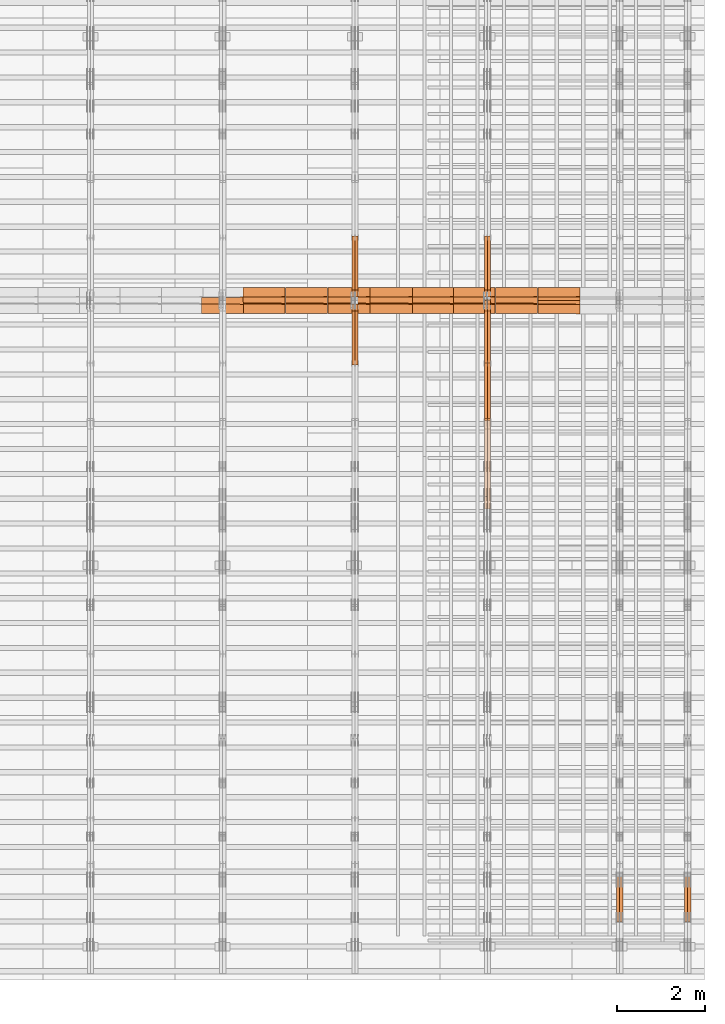
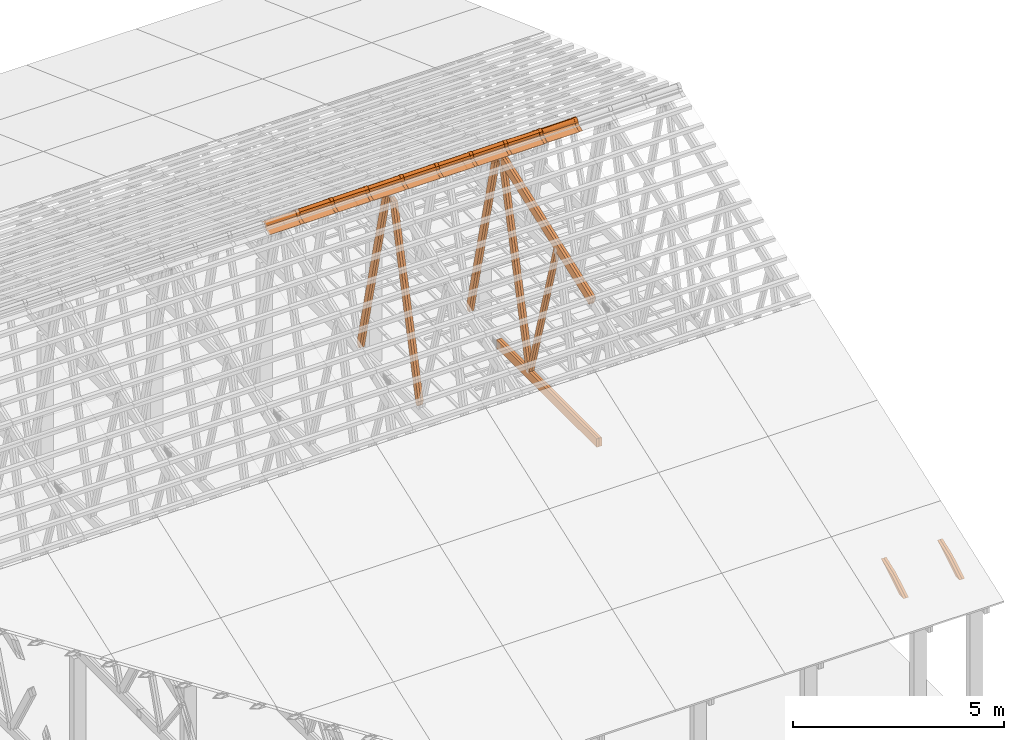
# One storey, part 53 of 189: 35 proxies.
"""IFC2X3 building model written with IfcOpenShell, lengths in millimetres."""

from ifc_helpers import new_model, entity, si_unit, converted_unit, derived_unit, direction, frame, frame_2d, origin, origin_2d_with_axis, place, context, subcontext, project, spatial, polyline, circle_curve, parameter, trimmed, segment, composite_curve, rectangle, outline, extrude, source, transform, mapped, material, type_object, type_shapes, element, save


model = new_model("IFC2X3")

# Units and contexts
model_context = context("Model", 3, precision=0.01, world=origin(), true_north=direction((6.12303176911189e-17, 1.0)))
body_context = subcontext(model_context, "Body", "Model", "MODEL_VIEW")
ifc_project = project(units=[si_unit("LENGTHUNIT", "METRE", prefix="MILLI"), si_unit("AREAUNIT", "SQUARE_METRE"), si_unit("VOLUMEUNIT", "CUBIC_METRE"), converted_unit("PLANEANGLEUNIT", "DEGREE", entity("IfcRatioMeasure", 0.0174532925199433), si_unit("PLANEANGLEUNIT", "RADIAN"), dimensions=[0, 0, 0, 0, 0, 0, 0]), si_unit("MASSUNIT", "GRAM", prefix="KILO"), derived_unit("MASSDENSITYUNIT", [(si_unit("MASSUNIT", "GRAM", prefix="KILO"), 1), (si_unit("LENGTHUNIT", "METRE"), -3)]), si_unit("TIMEUNIT", "SECOND"), si_unit("FREQUENCYUNIT", "HERTZ"), si_unit("THERMODYNAMICTEMPERATUREUNIT", "DEGREE_CELSIUS"), derived_unit("THERMALTRANSMITTANCEUNIT", [(si_unit("MASSUNIT", "GRAM", prefix="KILO"), 1), (si_unit("THERMODYNAMICTEMPERATUREUNIT", "KELVIN"), -1), (si_unit("TIMEUNIT", "SECOND"), -3)]), derived_unit("VOLUMETRICFLOWRATEUNIT", [(si_unit("LENGTHUNIT", "METRE"), 3), (si_unit("TIMEUNIT", "SECOND"), -1)]), si_unit("ELECTRICCURRENTUNIT", "AMPERE"), si_unit("ELECTRICVOLTAGEUNIT", "VOLT"), si_unit("POWERUNIT", "WATT"), si_unit("FORCEUNIT", "NEWTON"), si_unit("ILLUMINANCEUNIT", "LUX"), si_unit("LUMINOUSFLUXUNIT", "LUMEN"), si_unit("LUMINOUSINTENSITYUNIT", "CANDELA"), derived_unit("USERDEFINED", [(si_unit("MASSUNIT", "GRAM", prefix="KILO"), -1), (si_unit("LENGTHUNIT", "METRE"), -2), (si_unit("TIMEUNIT", "SECOND"), 3), (si_unit("LUMINOUSFLUXUNIT", "LUMEN"), 1)]), derived_unit("LINEARVELOCITYUNIT", [(si_unit("LENGTHUNIT", "METRE"), 1), (si_unit("TIMEUNIT", "SECOND"), -1)]), si_unit("PRESSUREUNIT", "PASCAL"), derived_unit("USERDEFINED", [(si_unit("LENGTHUNIT", "METRE"), -2), (si_unit("MASSUNIT", "GRAM", prefix="KILO"), 1), (si_unit("TIMEUNIT", "SECOND"), -2)])], contexts=[model_context])

# Site, building, storey
site_placement = place(None, origin())
site = spatial("IfcSite", under=ifc_project, at=site_placement, CompositionType="ELEMENT")
building_placement = place(site_placement, origin())
building = spatial("IfcBuilding", under=site, at=building_placement, CompositionType="ELEMENT")
storey_placement = place(building_placement, origin())
storey = spatial("IfcBuildingStorey", under=building, at=storey_placement, Name="Default", CompositionType="ELEMENT", Elevation=0.0)

# Proxies
ifc_material_1 = material(Name="IfcSurfaceStyle #270208")
building_element_proxy_type_1 = type_object("IfcBuildingElementProxyType", Name="T1-W12 270206", PredefinedType="NOTDEFINED", material=ifc_material_1)
shared_shape_1 = source(origin(), body_context, "Body", "SweptSolid", [
    extrude(outline(polyline([(-671.888430889784, -47.499785620702), (344.892972119224, -47.499785620702), (503.856463083211, 47.4997856207019), (-176.861004312651, 47.499785620702), (-671.888430889784, -47.499785620702)])), frame((503.857114243549, 47.5002636410509, 0.0), z_axis=(0.0, 0.0, 1.0), x_axis=(-1.0, 0.0, 0.0)), (0.0, 0.0, 1.0), 69.9999999999999),
])
type_shapes(building_element_proxy_type_1, [shared_shape_1])
proxy_1_placement = place(building_placement, frame((49840.0, 665.58122707747, 245.000076287477), z_axis=(-1.0, 0.0, 0.0), x_axis=(0.0, 0.858392121304013, 0.51299411895576)))
element("IfcBuildingElementProxy", 1, at=proxy_1_placement, inside=storey, type_object=building_element_proxy_type_1, material=ifc_material_1, Name="T1-W12", context=body_context, shape_type="MappedRepresentation", body=[
    mapped(shared_shape_1, transform((0.0, 0.0, 0.0), scale=1.0)),
])
ifc_material_2 = material(Name="IfcSurfaceStyle #270151")
building_element_proxy_type_2 = type_object("IfcBuildingElementProxyType", Name="T1-W12 270149", PredefinedType="NOTDEFINED", material=ifc_material_2)
shared_shape_2 = source(origin(), body_context, "Body", "SweptSolid", [
    extrude(outline(polyline([(-671.888430889784, -47.499785620702), (344.892972119224, -47.499785620702), (503.856463083211, 47.4997856207019), (-176.861004312651, 47.499785620702), (-671.888430889784, -47.499785620702)])), frame((503.857114243549, 47.5002636410509, 0.0), z_axis=(0.0, 0.0, 1.0), x_axis=(-1.0, 0.0, 0.0)), (0.0, 0.0, 1.0), 69.9999999999999),
])
type_shapes(building_element_proxy_type_2, [shared_shape_2])
proxy_2_placement = place(building_placement, frame((49770.0, 665.58122707747, 245.000076287477), z_axis=(-1.0, 0.0, 0.0), x_axis=(0.0, 0.858392121304013, 0.51299411895576)))
element("IfcBuildingElementProxy", 2, at=proxy_2_placement, inside=storey, type_object=building_element_proxy_type_2, material=ifc_material_2, Name="T1-W12", context=body_context, shape_type="MappedRepresentation", body=[
    mapped(shared_shape_2, transform((0.0, 0.0, 0.0), scale=1.0)),
])
ifc_material_3 = material(Name="IfcSurfaceStyle #254418")
building_element_proxy_type_3 = type_object("IfcBuildingElementProxyType", Name="T1-W12 254416", PredefinedType="NOTDEFINED", material=ifc_material_3)
shared_shape_3 = source(origin(), body_context, "Body", "SweptSolid", [
    extrude(outline(polyline([(-671.888430889784, -47.499785620702), (344.892972119224, -47.499785620702), (503.856463083211, 47.4997856207019), (-176.861004312651, 47.499785620702), (-671.888430889784, -47.499785620702)])), frame((503.857114243549, 47.5002636410509, 0.0), z_axis=(0.0, 0.0, 1.0), x_axis=(-1.0, 0.0, 0.0)), (0.0, 0.0, 1.0), 69.9999999999999),
])
type_shapes(building_element_proxy_type_3, [shared_shape_3])
proxy_3_placement = place(building_placement, frame((48300.0, 665.58122707747, 245.000076287477), z_axis=(-1.0, 0.0, 0.0), x_axis=(0.0, 0.858392121304013, 0.51299411895576)))
element("IfcBuildingElementProxy", 3, at=proxy_3_placement, inside=storey, type_object=building_element_proxy_type_3, material=ifc_material_3, Name="T1-W12", context=body_context, shape_type="MappedRepresentation", body=[
    mapped(shared_shape_3, transform((0.0, 0.0, 0.0), scale=1.0)),
])
ifc_material_4 = material(Name="IfcSurfaceStyle #254361")
building_element_proxy_type_4 = type_object("IfcBuildingElementProxyType", Name="T1-W12 254359", PredefinedType="NOTDEFINED", material=ifc_material_4)
shared_shape_4 = source(origin(), body_context, "Body", "SweptSolid", [
    extrude(outline(polyline([(-671.888430889784, -47.499785620702), (344.892972119224, -47.499785620702), (503.856463083211, 47.4997856207019), (-176.861004312651, 47.499785620702), (-671.888430889784, -47.499785620702)])), frame((503.857114243549, 47.5002636410509, 0.0), z_axis=(0.0, 0.0, 1.0), x_axis=(-1.0, 0.0, 0.0)), (0.0, 0.0, 1.0), 69.9999999999999),
])
type_shapes(building_element_proxy_type_4, [shared_shape_4])
proxy_4_placement = place(building_placement, frame((48230.0, 665.58122707747, 245.000076287477), z_axis=(-1.0, 0.0, 0.0), x_axis=(0.0, 0.858392121304013, 0.51299411895576)))
element("IfcBuildingElementProxy", 4, at=proxy_4_placement, inside=storey, type_object=building_element_proxy_type_4, material=ifc_material_4, Name="T1-W12", context=body_context, shape_type="MappedRepresentation", body=[
    mapped(shared_shape_4, transform((0.0, 0.0, 0.0), scale=1.0)),
])
ifc_material_5 = material(Name="IfcSurfaceStyle #242324")
building_element_proxy_type_5 = type_object("IfcBuildingElementProxyType", Name="T1-W5 242322", PredefinedType="NOTDEFINED", material=ifc_material_5)
shared_shape_5 = source(origin(), body_context, "Body", "SweptSolid", [
    extrude(outline(polyline([(-3233.61216530572, -72.4999091305202), (2153.79187521892, -72.4999091305202), (2171.36968478227, -7.18521572819375e-05), (2045.62106208646, 72.4999450565989), (-3137.17045678193, 72.4999450565989), (-3233.61216530572, -72.4999091305202)])), frame((2171.36968478227, 72.500192121173, 0.0), z_axis=(0.0, 0.0, 1.0), x_axis=(-1.0, 0.0, 0.0)), (0.0, 0.0, 1.0), 69.9999999999997),
])
type_shapes(building_element_proxy_type_5, [shared_shape_5])
proxy_5_placement = place(building_placement, frame((45300.0, 13261.0146935344, 262.082919891325), z_axis=(-1.0, 0.0, 0.0), x_axis=(0.0, 0.235625623344066, 0.97184389982328)))
element("IfcBuildingElementProxy", 5, at=proxy_5_placement, inside=storey, type_object=building_element_proxy_type_5, material=ifc_material_5, Name="T1-W5", context=body_context, shape_type="MappedRepresentation", body=[
    mapped(shared_shape_5, transform((0.0, 0.0, 0.0), scale=1.0)),
])
ifc_material_6 = material(Name="IfcSurfaceStyle #242258")
building_element_proxy_type_6 = type_object("IfcBuildingElementProxyType", Name="T1-W5 242256", PredefinedType="NOTDEFINED", material=ifc_material_6)
shared_shape_6 = source(origin(), body_context, "Body", "SweptSolid", [
    extrude(outline(polyline([(-3233.61216530572, -72.4999091305202), (2153.79187521892, -72.4999091305202), (2171.36968478227, -7.18521572819375e-05), (2045.62106208646, 72.4999450565989), (-3137.17045678193, 72.4999450565989), (-3233.61216530572, -72.4999091305202)])), frame((2171.36968478227, 72.500192121173, 0.0), z_axis=(0.0, 0.0, 1.0), x_axis=(-1.0, 0.0, 0.0)), (0.0, 0.0, 1.0), 69.9999999999997),
])
type_shapes(building_element_proxy_type_6, [shared_shape_6])
proxy_6_placement = place(building_placement, frame((45230.0, 13261.0146935344, 262.082919891325), z_axis=(-1.0, 0.0, 0.0), x_axis=(0.0, 0.235625623344066, 0.97184389982328)))
element("IfcBuildingElementProxy", 6, at=proxy_6_placement, inside=storey, type_object=building_element_proxy_type_6, material=ifc_material_6, Name="T1-W5", context=body_context, shape_type="MappedRepresentation", body=[
    mapped(shared_shape_6, transform((0.0, 0.0, 0.0), scale=1.0)),
])
ifc_material_7 = material(Name="IfcSurfaceStyle #242192")
building_element_proxy_type_7 = type_object("IfcBuildingElementProxyType", Name="T1-W5 242190", PredefinedType="NOTDEFINED", material=ifc_material_7)
shared_shape_7 = source(origin(), body_context, "Body", "SweptSolid", [
    extrude(outline(polyline([(-3137.17045678193, -72.5002081306407), (2045.62106208646, -72.5002081306408), (2171.36968478227, 5.58426931168476e-05), (2153.79187521892, 72.5001802092942), (-3233.61216530572, 72.5001802092942), (-3137.17045678193, -72.5002081306407)])), frame((2171.36968478227, 72.5001802092942, 0.0), z_axis=(0.0, 0.0, 1.0), x_axis=(-1.0, 0.0, 0.0)), (0.0, 0.0, 1.0), 69.9999999999997),
])
type_shapes(building_element_proxy_type_7, [shared_shape_7])
proxy_7_placement = place(building_placement, frame((45300.0, 16098.0675635854, 227.917113003597), z_axis=(-1.0, 0.0, 0.0), x_axis=(0.0, -0.235625623344066, 0.971843899823279)))
element("IfcBuildingElementProxy", 7, at=proxy_7_placement, inside=storey, type_object=building_element_proxy_type_7, material=ifc_material_7, Name="T1-W5", context=body_context, shape_type="MappedRepresentation", body=[
    mapped(shared_shape_7, transform((0.0, 0.0, 0.0), scale=1.0)),
])
ifc_material_8 = material(Name="IfcSurfaceStyle #242126")
building_element_proxy_type_8 = type_object("IfcBuildingElementProxyType", Name="T1-W5 242124", PredefinedType="NOTDEFINED", material=ifc_material_8)
shared_shape_8 = source(origin(), body_context, "Body", "SweptSolid", [
    extrude(outline(polyline([(-3137.17045678193, -72.5002081306407), (2045.62106208646, -72.5002081306408), (2171.36968478227, 5.58426931168476e-05), (2153.79187521892, 72.5001802092942), (-3233.61216530572, 72.5001802092942), (-3137.17045678193, -72.5002081306407)])), frame((2171.36968478227, 72.5001802092942, 0.0), z_axis=(0.0, 0.0, 1.0), x_axis=(-1.0, 0.0, 0.0)), (0.0, 0.0, 1.0), 69.9999999999997),
])
type_shapes(building_element_proxy_type_8, [shared_shape_8])
proxy_8_placement = place(building_placement, frame((45230.0, 16098.0675635854, 227.917113003597), z_axis=(-1.0, 0.0, 0.0), x_axis=(0.0, -0.235625623344066, 0.971843899823279)))
element("IfcBuildingElementProxy", 8, at=proxy_8_placement, inside=storey, type_object=building_element_proxy_type_8, material=ifc_material_8, Name="T1-W5", context=body_context, shape_type="MappedRepresentation", body=[
    mapped(shared_shape_8, transform((0.0, 0.0, 0.0), scale=1.0)),
])
ifc_material_9 = material(Name="IfcSurfaceStyle #242060")
building_element_proxy_type_9 = type_object("IfcBuildingElementProxyType", Name="T1-W6 242058", PredefinedType="NOTDEFINED", material=ifc_material_9)
shared_shape_9 = source(origin(), body_context, "Body", "SweptSolid", [
    extrude(outline(polyline([(-2640.84340836012, -47.4996765865792), (1711.12245024294, -47.4996765865792), (1797.68490303083, -9.57690019346202e-05), (1800.72595169379, 47.4997244710801), (-2668.68989660745, 47.4997244710801), (-2640.84340836012, -47.4996765865792)])), frame((1800.72595169379, 47.5003009358159, 0.0), z_axis=(0.0, 0.0, 1.0), x_axis=(-1.0, 0.0, 0.0)), (0.0, 0.0, 1.0), 69.9999999999997),
])
type_shapes(building_element_proxy_type_9, [shared_shape_9])
proxy_9_placement = place(building_placement, frame((45300.0, 12074.2896156894, 4533.9586582452), z_axis=(-1.0, 0.0, 0.0), x_axis=(0.0, 0.28128598310461, -0.959623986626467)))
element("IfcBuildingElementProxy", 9, at=proxy_9_placement, inside=storey, type_object=building_element_proxy_type_9, material=ifc_material_9, Name="T1-W6", context=body_context, shape_type="MappedRepresentation", body=[
    mapped(shared_shape_9, transform((0.0, 0.0, 0.0), scale=1.0)),
])
ifc_material_10 = material(Name="IfcSurfaceStyle #241994")
building_element_proxy_type_10 = type_object("IfcBuildingElementProxyType", Name="T1-W6 241992", PredefinedType="NOTDEFINED", material=ifc_material_10)
shared_shape_10 = source(origin(), body_context, "Body", "SweptSolid", [
    extrude(outline(polyline([(-2640.84340836012, -47.4996765865792), (1711.12245024294, -47.4996765865792), (1797.68490303083, -9.57690019346202e-05), (1800.72595169379, 47.4997244710801), (-2668.68989660745, 47.4997244710801), (-2640.84340836012, -47.4996765865792)])), frame((1800.72595169379, 47.5003009358159, 0.0), z_axis=(0.0, 0.0, 1.0), x_axis=(-1.0, 0.0, 0.0)), (0.0, 0.0, 1.0), 69.9999999999997),
])
type_shapes(building_element_proxy_type_10, [shared_shape_10])
proxy_10_placement = place(building_placement, frame((45230.0, 12074.2896156894, 4533.9586582452), z_axis=(-1.0, 0.0, 0.0), x_axis=(0.0, 0.28128598310461, -0.959623986626467)))
element("IfcBuildingElementProxy", 10, at=proxy_10_placement, inside=storey, type_object=building_element_proxy_type_10, material=ifc_material_10, Name="T1-W6", context=body_context, shape_type="MappedRepresentation", body=[
    mapped(shared_shape_10, transform((0.0, 0.0, 0.0), scale=1.0)),
])
ifc_material_11 = material(Name="IfcSurfaceStyle #238040")
building_element_proxy_type_11 = type_object("IfcBuildingElementProxyType", Name="T1-B3 238038", PredefinedType="NOTDEFINED", material=ifc_material_11)
shared_shape_11 = source(origin(), body_context, "Body", "SweptSolid", [
    extrude(rectangle(XDim=4751.0283203125, YDim=245.000000000001, at=origin_2d_with_axis()), frame((2375.51416015625, 122.5, 0.0), z_axis=(0.0, 0.0, 1.0), x_axis=(-1.0, 0.0, 0.0)), (0.0, 0.0, 1.0), 69.9999999999997),
])
type_shapes(building_element_proxy_type_11, [shared_shape_11])
proxy_11_placement = place(building_placement, frame((45300.0, 10029.23046875, 245.0), z_axis=(-1.0, 0.0, 0.0), x_axis=(0.0, 1.0, 0.0)))
element("IfcBuildingElementProxy", 11, at=proxy_11_placement, inside=storey, type_object=building_element_proxy_type_11, material=ifc_material_11, Name="T1-B3", context=body_context, shape_type="MappedRepresentation", body=[
    mapped(shared_shape_11, transform((0.0, 0.0, 0.0), scale=1.0)),
])
ifc_material_12 = material(Name="IfcSurfaceStyle #237983")
building_element_proxy_type_12 = type_object("IfcBuildingElementProxyType", Name="T1-B3 237981", PredefinedType="NOTDEFINED", material=ifc_material_12)
shared_shape_12 = source(origin(), body_context, "Body", "SweptSolid", [
    extrude(rectangle(XDim=4751.0283203125, YDim=245.000000000001, at=origin_2d_with_axis()), frame((2375.51416015625, 122.5, 0.0), z_axis=(0.0, 0.0, 1.0), x_axis=(-1.0, 0.0, 0.0)), (0.0, 0.0, 1.0), 69.9999999999997),
])
type_shapes(building_element_proxy_type_12, [shared_shape_12])
proxy_12_placement = place(building_placement, frame((45230.0, 10029.23046875, 245.0), z_axis=(-1.0, 0.0, 0.0), x_axis=(0.0, 1.0, 0.0)))
element("IfcBuildingElementProxy", 12, at=proxy_12_placement, inside=storey, type_object=building_element_proxy_type_12, material=ifc_material_12, Name="T1-B3", context=body_context, shape_type="MappedRepresentation", body=[
    mapped(shared_shape_12, transform((0.0, 0.0, 0.0), scale=1.0)),
])
ifc_material_13 = material(Name="IfcSurfaceStyle #237452")
building_element_proxy_type_13 = type_object("IfcBuildingElementProxyType", Name="T1-T3 237450", PredefinedType="NOTDEFINED", material=ifc_material_13)
shared_shape_13 = source(origin(), body_context, "Body", "SweptSolid", [
    extrude(outline(polyline([(-2341.64890001385, -122.499972785692), (2386.23525922045, -122.499972785692), (2297.06252495753, 122.499972785692), (-2341.64888416412, 122.499972785692), (-2341.64890001385, -122.499972785692)])), frame((2386.23525922045, 122.499973888764, 0.0), z_axis=(0.0, 0.0, 1.0), x_axis=(-1.0, 0.0, 0.0)), (0.0, 0.0, 1.0), 69.9999999999997),
])
type_shapes(building_element_proxy_type_13, [shared_shape_13])
proxy_13_placement = place(building_placement, frame((45300.0, 14833.7949607394, 5538.33627266055), z_axis=(-1.0, 0.0, 0.0), x_axis=(0.0, -0.939692620785908, -0.342020143325669)))
element("IfcBuildingElementProxy", 13, at=proxy_13_placement, inside=storey, type_object=building_element_proxy_type_13, material=ifc_material_13, Name="T1-T3", context=body_context, shape_type="MappedRepresentation", body=[
    mapped(shared_shape_13, transform((0.0, 0.0, 0.0), scale=1.0)),
])
ifc_material_14 = material(Name="IfcSurfaceStyle #237395")
building_element_proxy_type_14 = type_object("IfcBuildingElementProxyType", Name="T1-T3 237393", PredefinedType="NOTDEFINED", material=ifc_material_14)
shared_shape_14 = source(origin(), body_context, "Body", "SweptSolid", [
    extrude(outline(polyline([(-2341.64890001385, -122.499972785692), (2386.23525922045, -122.499972785692), (2297.06252495753, 122.499972785692), (-2341.64888416412, 122.499972785692), (-2341.64890001385, -122.499972785692)])), frame((2386.23525922045, 122.499973888764, 0.0), z_axis=(0.0, 0.0, 1.0), x_axis=(-1.0, 0.0, 0.0)), (0.0, 0.0, 1.0), 69.9999999999997),
])
type_shapes(building_element_proxy_type_14, [shared_shape_14])
proxy_14_placement = place(building_placement, frame((45230.0, 14833.7949607394, 5538.33627266055), z_axis=(-1.0, 0.0, 0.0), x_axis=(0.0, -0.939692620785908, -0.342020143325669)))
element("IfcBuildingElementProxy", 14, at=proxy_14_placement, inside=storey, type_object=building_element_proxy_type_14, material=ifc_material_14, Name="T1-T3", context=body_context, shape_type="MappedRepresentation", body=[
    mapped(shared_shape_14, transform((0.0, 0.0, 0.0), scale=1.0)),
])
ifc_material_15 = material(Name="IfcSurfaceStyle #226534")
building_element_proxy_type_15 = type_object("IfcBuildingElementProxyType", Name="T1-W5 226532", PredefinedType="NOTDEFINED", material=ifc_material_15)
shared_shape_15 = source(origin(), body_context, "Body", "SweptSolid", [
    extrude(outline(polyline([(-3233.61216530572, -72.4999091305202), (2153.79187521892, -72.4999091305202), (2171.36968478227, -7.18521572819375e-05), (2045.62106208646, 72.4999450565989), (-3137.17045678193, 72.4999450565989), (-3233.61216530572, -72.4999091305202)])), frame((2171.36968478227, 72.500192121173, 0.0), z_axis=(0.0, 0.0, 1.0), x_axis=(-1.0, 0.0, 0.0)), (0.0, 0.0, 1.0), 69.9999999999997),
])
type_shapes(building_element_proxy_type_15, [shared_shape_15])
proxy_15_placement = place(building_placement, frame((42300.0, 13261.0146935344, 262.082919891325), z_axis=(-1.0, 0.0, 0.0), x_axis=(0.0, 0.235625623344066, 0.97184389982328)))
element("IfcBuildingElementProxy", 15, at=proxy_15_placement, inside=storey, type_object=building_element_proxy_type_15, material=ifc_material_15, Name="T1-W5", context=body_context, shape_type="MappedRepresentation", body=[
    mapped(shared_shape_15, transform((0.0, 0.0, 0.0), scale=1.0)),
])
ifc_material_16 = material(Name="IfcSurfaceStyle #226468")
building_element_proxy_type_16 = type_object("IfcBuildingElementProxyType", Name="T1-W5 226466", PredefinedType="NOTDEFINED", material=ifc_material_16)
shared_shape_16 = source(origin(), body_context, "Body", "SweptSolid", [
    extrude(outline(polyline([(-3233.61216530572, -72.4999091305202), (2153.79187521892, -72.4999091305202), (2171.36968478227, -7.18521572819375e-05), (2045.62106208646, 72.4999450565989), (-3137.17045678193, 72.4999450565989), (-3233.61216530572, -72.4999091305202)])), frame((2171.36968478227, 72.500192121173, 0.0), z_axis=(0.0, 0.0, 1.0), x_axis=(-1.0, 0.0, 0.0)), (0.0, 0.0, 1.0), 69.9999999999997),
])
type_shapes(building_element_proxy_type_16, [shared_shape_16])
proxy_16_placement = place(building_placement, frame((42230.0, 13261.0146935344, 262.082919891325), z_axis=(-1.0, 0.0, 0.0), x_axis=(0.0, 0.235625623344066, 0.97184389982328)))
element("IfcBuildingElementProxy", 16, at=proxy_16_placement, inside=storey, type_object=building_element_proxy_type_16, material=ifc_material_16, Name="T1-W5", context=body_context, shape_type="MappedRepresentation", body=[
    mapped(shared_shape_16, transform((0.0, 0.0, 0.0), scale=1.0)),
])
ifc_material_17 = material(Name="IfcSurfaceStyle #226402")
building_element_proxy_type_17 = type_object("IfcBuildingElementProxyType", Name="T1-W5 226400", PredefinedType="NOTDEFINED", material=ifc_material_17)
shared_shape_17 = source(origin(), body_context, "Body", "SweptSolid", [
    extrude(outline(polyline([(-3137.17045678193, -72.5002081306407), (2045.62106208646, -72.5002081306408), (2171.36968478227, 5.58426931168476e-05), (2153.79187521892, 72.5001802092942), (-3233.61216530572, 72.5001802092942), (-3137.17045678193, -72.5002081306407)])), frame((2171.36968478227, 72.5001802092942, 0.0), z_axis=(0.0, 0.0, 1.0), x_axis=(-1.0, 0.0, 0.0)), (0.0, 0.0, 1.0), 69.9999999999997),
])
type_shapes(building_element_proxy_type_17, [shared_shape_17])
proxy_17_placement = place(building_placement, frame((42300.0, 16098.0675635854, 227.917113003597), z_axis=(-1.0, 0.0, 0.0), x_axis=(0.0, -0.235625623344066, 0.971843899823279)))
element("IfcBuildingElementProxy", 17, at=proxy_17_placement, inside=storey, type_object=building_element_proxy_type_17, material=ifc_material_17, Name="T1-W5", context=body_context, shape_type="MappedRepresentation", body=[
    mapped(shared_shape_17, transform((0.0, 0.0, 0.0), scale=1.0)),
])
ifc_material_18 = material(Name="IfcSurfaceStyle #226336")
building_element_proxy_type_18 = type_object("IfcBuildingElementProxyType", Name="T1-W5 226334", PredefinedType="NOTDEFINED", material=ifc_material_18)
shared_shape_18 = source(origin(), body_context, "Body", "SweptSolid", [
    extrude(outline(polyline([(-3137.17045678193, -72.5002081306407), (2045.62106208646, -72.5002081306408), (2171.36968478227, 5.58426931168476e-05), (2153.79187521892, 72.5001802092942), (-3233.61216530572, 72.5001802092942), (-3137.17045678193, -72.5002081306407)])), frame((2171.36968478227, 72.5001802092942, 0.0), z_axis=(0.0, 0.0, 1.0), x_axis=(-1.0, 0.0, 0.0)), (0.0, 0.0, 1.0), 69.9999999999997),
])
type_shapes(building_element_proxy_type_18, [shared_shape_18])
proxy_18_placement = place(building_placement, frame((42230.0, 16098.0675635854, 227.917113003597), z_axis=(-1.0, 0.0, 0.0), x_axis=(0.0, -0.235625623344066, 0.971843899823279)))
element("IfcBuildingElementProxy", 18, at=proxy_18_placement, inside=storey, type_object=building_element_proxy_type_18, material=ifc_material_18, Name="T1-W5", context=body_context, shape_type="MappedRepresentation", body=[
    mapped(shared_shape_18, transform((0.0, 0.0, 0.0), scale=1.0)),
])
ifc_material_19 = material()
building_element_proxy_type_19 = type_object("IfcBuildingElementProxyType", Name="P75", PredefinedType="NOTDEFINED", material=ifc_material_19)
shared_shape_19 = source(origin(), body_context, "Body", "SweptSolid", [
    extrude(outline(composite_curve([segment(polyline([(-69.4623915065845, -4.60763114971976), (47.4521071665907, -4.60763114971981)]), True, "CONTINUOUS"), segment(trimmed(circle_curve(frame_2d((119.940978060963, 14.6372018310859), x_axis=(-0.966518278591622, -0.256597773077395)), 75.0), [parameter(6.61555373744412e-13)], [parameter(180.0)], True, "PARAMETER"), True, "CONTINUOUS"), segment(polyline([(192.429848955335, 33.882034811891), (182.764666169419, 31.3160570811166)]), True, "CONTINUOUS"), segment(trimmed(circle_curve(frame_2d((119.940978060963, 14.6372018310859), x_axis=(-0.966518278591622, -0.256597773077395)), 65.0), [parameter(1.06866637297174e-12)], [parameter(180.0)], True, "PARAMETER"), False, "CONTINUOUS"), segment(polyline([(57.1172899525073, -2.04165341894578), (47.4521071665911, 5.39236885028051)]), True, "CONTINUOUS"), segment(polyline([(47.4521071665911, 5.39236885028052), (-70.7672243976422, 5.39236885028094)]), True, "CONTINUOUS"), segment(polyline([(-70.7672243976422, 5.39236885028094), (-194.776190618495, -27.5303655446341)]), True, "CONTINUOUS"), segment(polyline([(-194.776190618495, -27.5303655446341), (-192.210212887721, -37.1955483305503)]), True, "CONTINUOUS"), segment(polyline([(-192.210212887721, -37.1955483305503), (-69.4623915065845, -4.60763114971974)]), True, "CONTINUOUS")], self_intersect=False)), frame((0.0, 106.775760402721, -56.5599052870917), z_axis=(1.0, 0.0, 0.0), x_axis=(0.0, -0.820468487122275, 0.571691754041709)), (0.0, 0.0, 1.0), 867.000000000001),
    extrude(outline(composite_curve([segment(polyline([(62.2906866429439, -18.428943356533), (189.290686642944, -18.428943356533)]), True, "CONTINUOUS"), segment(polyline([(189.290686642944, -18.428943356533), (189.290686642944, -8.42894335653292)]), True, "CONTINUOUS"), segment(polyline([(189.290686642944, -8.42894335653292), (62.2906866429439, -8.42894335653294)]), True, "CONTINUOUS"), segment(polyline([(62.2906866429439, -8.42894335653294), (-41.0348065006093, 19.0026034957362)]), True, "CONTINUOUS"), segment(trimmed(circle_curve(frame_2d((-125.709313357056, 11.5710566434651), x_axis=(1.0, 0.0)), 85.0), [parameter(5.01577186738723)], [parameter(180.0)], True, "PARAMETER"), True, "CONTINUOUS"), segment(polyline([(-210.709313357056, 11.5710566434656), (-200.709313357056, 11.5710566434656)]), True, "CONTINUOUS"), segment(trimmed(circle_curve(frame_2d((-125.709313357056, 11.5710566434651), x_axis=(1.0, 0.0)), 75.0), [parameter(3.05333249420498e-13)], [parameter(180.0)], True, "PARAMETER"), False, "CONTINUOUS"), segment(polyline([(-50.7093133570542, 11.5710566434655), (62.290686642944, -18.4289433565322)]), True, "CONTINUOUS")], self_intersect=False)), frame((867.0, 114.170579674061, -53.8683539143053), z_axis=(1.0, 0.0, 0.0), x_axis=(0.0, 0.939692620785914, -0.342020143325653)), (0.0, 0.0, 1.0), 86.9999999999998),
])
type_shapes(building_element_proxy_type_19, [shared_shape_19])
for number, where, name in (
    (19, (46372.9353253273, 14755.0000438631, 5865.69618295448), "P75, generic model20:P75"),
    (20, (45412.9353253273, 14755.0000438631, 5865.69618295448), "P75, generic model20:P75"),
    (21, (44452.9353253273, 14755.0000438631, 5865.69618295448), "P75, generic model20:P75"),
    (22, (43512.9353253273, 14755.0000438631, 5865.69618295448), "P75, generic model20:P75"),
    (23, (42572.9353253273, 14755.0000438631, 5865.69618295448), "P75, generic model20:P75"),
    (24, (41612.9353253273, 14755.0000438631, 5865.69618295448), "P75, generic model20:P75"),
    (25, (40652.9353253273, 14755.0000438631, 5865.69618295448), "P75, generic model20:P75"),
    (26, (39692.9353253273, 14755.0000438631, 5865.69618295448), "P75, generic model20:P75"),
):
    element("IfcBuildingElementProxy", number, at=place(storey_placement, frame(where)), inside=storey, type_object=building_element_proxy_type_19, material=ifc_material_19, Name=name, ObjectType="P75, generic model20:P75", context=body_context, shape_type="MappedRepresentation", body=[
        mapped(shared_shape_19, transform((0.0, 0.0, 0.0), scale=1.0)),
    ])
building_element_proxy_type_20 = type_object("IfcBuildingElementProxyType", Name="P75", PredefinedType="NOTDEFINED", material=ifc_material_19)
shared_shape_20 = source(origin(), body_context, "Body", "SweptSolid", [
    extrude(outline(composite_curve([segment(polyline([(68.3189789579817, 13.3705352460084), (195.318978957982, 13.3705352460084)]), True, "CONTINUOUS"), segment(polyline([(195.318978957982, 13.3705352460084), (195.318978957982, 23.3705352460084)]), True, "CONTINUOUS"), segment(polyline([(195.318978957982, 23.3705352460084), (67.014146066922, 23.3705352460088)]), True, "CONTINUOUS"), segment(polyline([(67.014146066922, 23.3705352460088), (-47.2469987727929, -6.96428196807339)]), True, "CONTINUOUS"), segment(polyline([(-47.2469987727929, -6.96428196807339), (-54.6810210420187, -16.62946475399)]), True, "CONTINUOUS"), segment(trimmed(circle_curve(frame_2d((-119.681021042019, -16.6294647539896), x_axis=(1.0, 0.0)), 65.0), [parameter(180.0)], [parameter(359.999999999999)], True, "PARAMETER"), False, "CONTINUOUS"), segment(polyline([(-184.681021042019, -16.6294647539905), (-194.681021042019, -16.6294647539901)]), True, "CONTINUOUS"), segment(trimmed(circle_curve(frame_2d((-119.681021042019, -16.6294647539896), x_axis=(1.0, 0.0)), 75.0), [parameter(180.0)], [parameter(359.999999999999)], True, "PARAMETER"), True, "CONTINUOUS"), segment(polyline([(-44.6810210420183, -16.6294647539898), (68.3189789579816, 13.3705352460083)]), True, "CONTINUOUS")], self_intersect=False)), frame((0.0, -106.775760402721, -56.5599052870916), z_axis=(1.0, 0.0, 0.0), x_axis=(0.0, -0.939692620785914, -0.342020143325654)), (0.0, 0.0, 1.0), 867.000000000001),
    extrude(outline(composite_curve([segment(polyline([(-64.9339130518847, 1.82825913317695), (-187.681734433021, -30.7596580476538)]), True, "CONTINUOUS"), segment(polyline([(-187.681734433021, -30.7596580476538), (-185.115756702247, -40.4248408335702)]), True, "CONTINUOUS"), segment(polyline([(-185.115756702247, -40.4248408335702), (-62.3679353211107, -7.83692365273935)]), True, "CONTINUOUS"), segment(polyline([(-62.3679353211107, -7.83692365273935), (44.5369162809878, -7.83692365273935)]), True, "CONTINUOUS"), segment(trimmed(circle_curve(frame_2d((124.469456515662, 21.0730921139827), x_axis=(-0.966518278591636, -0.256597773077402)), 85.0), [parameter(5.01577186738723)], [parameter(180.0)], True, "PARAMETER"), True, "CONTINUOUS"), segment(polyline([(206.623510195951, 42.8839028255618), (196.958327410034, 40.3179250947878)]), True, "CONTINUOUS"), segment(trimmed(circle_curve(frame_2d((124.469456515662, 21.0730921139827), x_axis=(-0.966518278591636, -0.256597773077402)), 75.0), [parameter(3.05333249420498e-13)], [parameter(180.0)], True, "PARAMETER"), False, "CONTINUOUS"), segment(polyline([(51.9805856212887, 1.82825913317622), (-64.9339130518846, 1.82825913317621)]), True, "CONTINUOUS")], self_intersect=False)), frame((867.0, -114.170579674061, -53.868353914305), z_axis=(-1.0, 0.0, 0.0), x_axis=(0.0, 0.820468487122275, 0.571691754041709)), (0.0, 0.0, -1.0), 86.9999999999998),
])
type_shapes(building_element_proxy_type_20, [shared_shape_20])
for number, where, name in (
    (27, (46372.9353253273, 14739.222651576, 5866.56942296548), "P75, generic model20:P75"),
    (28, (45412.9353253273, 14745.0000384613, 5850.69618295448), "P75, generic model20:P75"),
    (29, (44452.9353253273, 14745.0000384613, 5850.69618295448), "P75, generic model20:P75"),
    (30, (43512.9353253273, 14745.0000384613, 5850.69618295448), "P75, generic model20:P75"),
    (31, (42572.9353253273, 14745.0000384613, 5850.69618295448), "P75, generic model20:P75"),
    (32, (41612.9353253273, 14745.0000384613, 5850.69618295448), "P75, generic model20:P75"),
    (33, (40652.9353253273, 14745.0000384613, 5850.69618295448), "P75, generic model20:P75"),
    (34, (39692.9353253273, 14745.0000384613, 5850.69618295448), "P75, generic model20:P75"),
    (35, (38752.9353253273, 14745.0000384613, 5850.69618295448), "P75, generic model20:P75"),
):
    element("IfcBuildingElementProxy", number, at=place(storey_placement, frame(where)), inside=storey, type_object=building_element_proxy_type_20, material=ifc_material_19, Name=name, ObjectType="P75, generic model20:P75", context=body_context, shape_type="MappedRepresentation", body=[
        mapped(shared_shape_20, transform((0.0, 0.0, 0.0), scale=1.0)),
    ])

save(model, "model.ifc")
